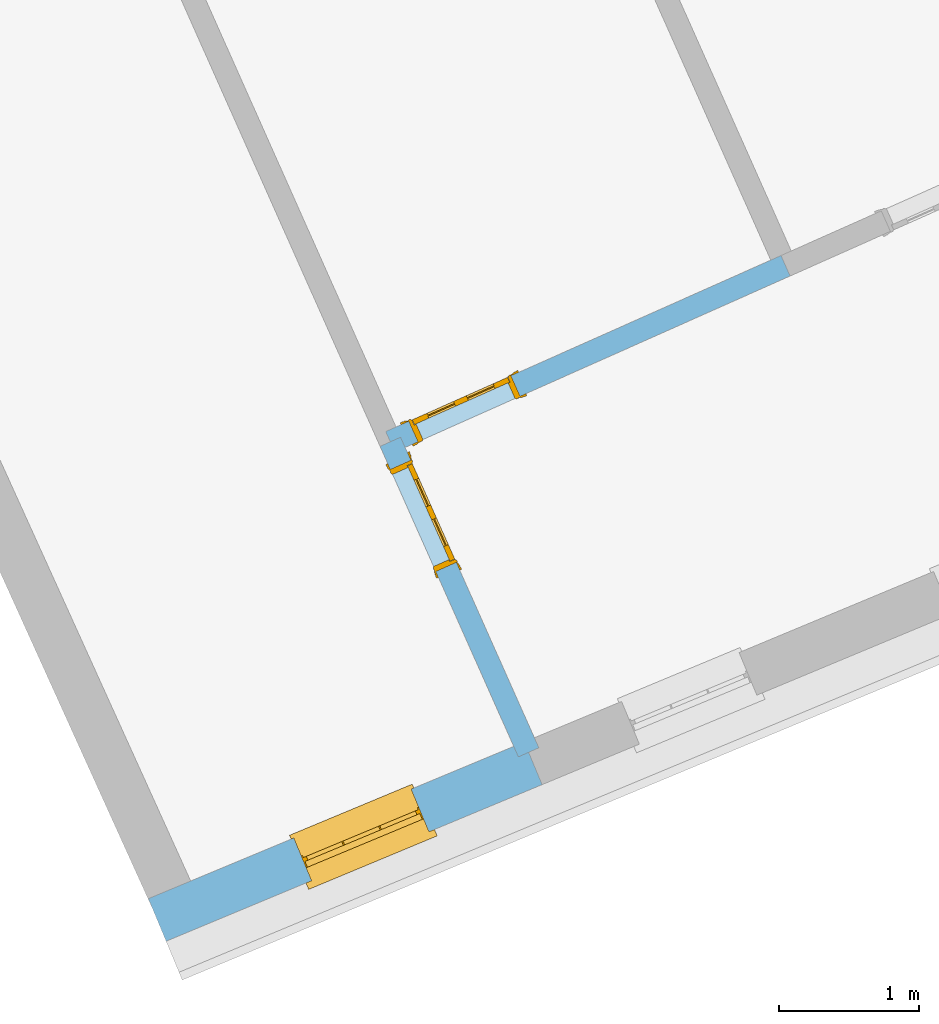
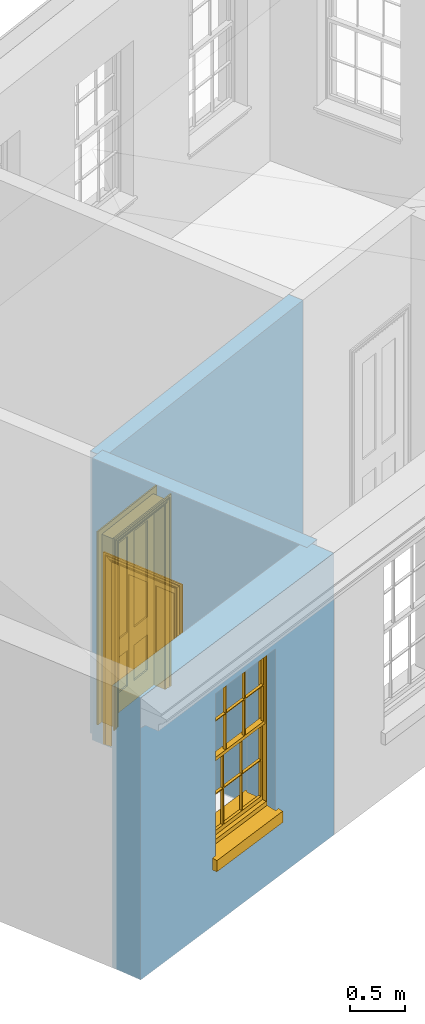
# One storey, part 2 of 10: 2 doors, 1 window, 3 openings, plus 3 elements that do not belong to this part.
"""IFC2X3 building model written with IfcOpenShell, lengths in metres."""

from ifc_helpers import new_model, si_unit, frame, origin, place, context, subcontext, project, spatial, polyline, outline, extrude, faceted_brep, material, layer, layer_set, layer_usage, element, fill, save


model = new_model("IFC2X3")

# Units and contexts
model_context = context("Model", 3, world=origin())
body_context = subcontext(model_context, "Body", "Model", "MODEL_VIEW")
ifc_project = project(units=[si_unit("PLANEANGLEUNIT", "RADIAN"), si_unit("MASSUNIT", "GRAM", prefix="KILO"), si_unit("FORCEUNIT", "NEWTON", prefix="KILO"), si_unit("LENGTHUNIT", "METRE")], contexts=[model_context])

# Site, building, storey
site_placement = place(None, origin())
site = spatial("IfcSite", under=ifc_project, at=site_placement, CompositionType="ELEMENT")
building_placement = place(None, origin())
building = spatial("IfcBuilding", under=site, at=building_placement, Name="Building plot-1", CompositionType="ELEMENT")
storey_placement = place(None, frame((0.0, 0.0, 8.45)))
storey = spatial("IfcBuildingStorey", under=building, at=storey_placement, Name="Floor 2", CompositionType="ELEMENT", Elevation=8.45)

# Wall, opening, window
ifc_material_1 = material(Name="Masonry")
ifc_layer_1 = layer(ifc_material_1, 0.33, ventilated=False)
ifc_layer_set_1 = layer_set([ifc_layer_1], Name="My Wall")
ifc_layer_usage_1 = layer_usage(ifc_layer_set_1, "AXIS2", "NEGATIVE", 0.08)
wall_1_placement = place(storey_placement, origin())
wall_1 = element("IfcWallStandardCase", 1, at=wall_1_placement, inside=storey, material=ifc_layer_usage_1, Name="exterior", context=body_context, shape_type="SweptSolid", body=[
    extrude(outline(polyline([(21.5557040167118, 40.2736905266135), (21.6826157364214, 39.9690704100743), (24.3699915253352, 41.0886927342715), (24.2430798056257, 41.3933128508107), (21.5557040167118, 40.2736905266135)])), origin(), (0.0, 0.0, 1.0), 3.15),
])
opening_1_placement = place(storey_placement, frame((0.0, 0.0, 0.75)))
opening_1 = element("IfcOpeningElement", 2, at=opening_1_placement, cuts=wall_1, Name="Opening", ObjectType="Opening", context=body_context, shape_type="SweptSolid", body=[
    extrude(outline(polyline([(22.7216835143391, 40.4019698524633), (23.5616965629775, 40.7519385340866), (23.434784843268, 41.0565586506259), (22.5947717946295, 40.7065899690026), (22.7216835143391, 40.4019698524633)])), origin(), (0.0, 0.0, 1.0), 1.82),
])
window_placement = place(storey_placement, frame((22.6255382721349, 40.6327426680233, 0.75), z_axis=(0.0, 0.0, 1.0), x_axis=(0.840013048638443, 0.349968681623302, 0.0)))
window = element("IfcWindow", 3, at=window_placement, inside=storey, Name="bedroom outside window", OverallHeight=1.82, OverallWidth=0.91, context=body_context, shape_type="Brep", held_by="IfcProductRepresentation", body=[
    faceted_brep([(0.033125, -0.105, 0.975209), (0.01, -0.105, 0.975209), (0.033125, -0.105, 1.376042), (0.876875, -0.105, 0.975209), (0.876875, -0.105, 1.376042), (0.9, -0.105, 0.975209), (0.876875, -0.105, 1.386042), (0.876875, -0.105, 1.786875), (0.9, -0.105, 1.81), (0.033125, -0.105, 1.786875), (0.033125, -0.105, 1.386042), (0.01, -0.105, 1.81), (0.876875, -0.135, 1.376042), (0.876875, -0.135, 0.975209), (0.9, -0.135, 0.937083), (0.033125, -0.135, 1.786875), (0.01, -0.135, 1.81), (0.033125, -0.135, 1.386042), (0.01, -0.135, 0.937083), (0.033125, -0.135, 0.975209), (0.033125, -0.135, 1.376042), (0.876875, -0.135, 1.786875), (0.876875, -0.135, 1.386042), (0.9, -0.135, 1.81), (0.033125, -0.105, 0.937083), (0.01, -0.105, 0.937083), (0.033125, -0.105, 0.53625), (0.876875, -0.105, 0.937083), (0.876875, -0.105, 0.53625), (0.9, -0.105, 0.937083), (0.876875, -0.105, 0.52625), (0.876875, -0.105, 0.125417), (0.9, -0.105, 0.077167), (0.033125, -0.105, 0.125417), (0.033125, -0.105, 0.52625), (0.01, -0.105, 0.077167), (-0.0425, -0.25, 0.01), (-0.0425, -0.3, 0.001667), (0.0, -0.25, 0.01), (0.9525, -0.25, 0.01), (0.91, -0.25, 0.01), (0.9525, -0.3, 0.001667), (-0.02, 0.08, 0.077167), (0.0, 0.08, 0.077167), (-0.02, 0.11, 0.077167), (0.0, -0.06, 0.077167), (0.01, -0.06, 0.077167), (0.91, -0.06, 0.077167), (0.91, 0.08, 0.077167), (0.9, -0.06, 0.077167), (0.93, 0.08, 0.077167), (0.93, 0.11, 0.077167), (0.01, -0.075, 0.975209), (0.9, -0.075, 0.975209), (0.876875, -0.075, 0.125417), (0.876875, -0.075, 0.52625), (0.9, -0.075, 0.077167), (0.876875, -0.075, 0.53625), (0.876875, -0.075, 0.937083), (0.033125, -0.075, 0.125417), (0.01, -0.075, 0.077167), (0.033125, -0.075, 0.52625), (0.033125, -0.075, 0.937083), (0.033125, -0.075, 0.53625), (-0.02, 0.08, 0.052167), (-0.02, 0.11, 0.052167), (0.93, 0.11, 0.052167), (0.93, 0.08, 0.052167), (0.91, 0.08, 0.052167), (0.0, 0.08, 0.052167), (0.91, -0.15, 0.026667), (0.0, -0.15, 0.026667), (-0.0425, -0.3, -0.123333), (0.9525, -0.3, -0.123333), (-0.0425, -0.25, -0.123333), (0.9525, -0.25, -0.123333), (0.01, -0.06, 1.81), (0.9, -0.06, 1.81), (0.0, -0.06, 1.82), (0.91, -0.06, 1.82), (0.01, -0.15, 0.077167), (0.9, -0.15, 0.077167), (0.592292, -0.105, 0.125417), (0.592292, -0.075, 0.125417), (0.317708, -0.075, 0.125417), (0.317708, -0.105, 0.125417), (0.592292, -0.105, 0.53625), (0.317708, -0.105, 0.53625), (0.317708, -0.105, 0.52625), (0.592292, -0.105, 0.52625), (0.592292, -0.075, 0.53625), (0.317708, -0.075, 0.53625), (0.592292, -0.135, 1.386042), (0.592292, -0.105, 1.386042), (0.317708, -0.105, 1.386042), (0.317708, -0.135, 1.386042), (0.317708, -0.135, 1.376042), (0.592292, -0.135, 1.376042), (0.317708, -0.105, 1.376042), (0.592292, -0.105, 1.376042), (0.602292, -0.135, 1.376042), (0.592292, -0.135, 0.975209), (0.602292, -0.135, 0.975209), (0.602292, -0.105, 0.975209), (0.592292, -0.105, 0.975209), (0.602292, -0.105, 1.376042), (0.602292, -0.075, 0.53625), (0.602292, -0.105, 0.53625), (0.317708, -0.075, 0.52625), (0.307708, -0.075, 0.125417), (0.307708, -0.075, 0.52625), (0.602292, -0.075, 0.52625), (0.602292, -0.075, 0.125417), (0.592292, -0.075, 0.52625), (0.307708, -0.075, 0.53625), (0.317708, -0.075, 0.937083), (0.307708, -0.075, 0.937083), (0.602292, -0.075, 0.937083), (0.592292, -0.075, 0.937083), (0.307708, -0.105, 0.52625), (0.307708, -0.105, 0.125417), (0.307708, -0.105, 0.53625), (0.307708, -0.105, 0.937083), (0.592292, -0.105, 0.937083), (0.317708, -0.105, 0.937083), (0.602292, -0.105, 0.937083), (0.602292, -0.105, 0.52625), (0.602292, -0.105, 0.125417), (0.307708, -0.135, 1.386042), (0.307708, -0.135, 1.376042), (0.307708, -0.135, 0.975209), (0.317708, -0.135, 0.975209), (0.317708, -0.135, 1.786875), (0.307708, -0.135, 1.786875), (0.602292, -0.135, 1.786875), (0.592292, -0.135, 1.786875), (0.602292, -0.135, 1.386042), (0.602292, -0.105, 1.386042), (0.307708, -0.105, 1.386042), (0.307708, -0.105, 1.786875), (0.317708, -0.105, 1.786875), (0.592292, -0.105, 1.786875), (0.602292, -0.105, 1.786875), (0.307708, -0.105, 1.376042), (0.317708, -0.105, 0.975209), (0.307708, -0.105, 0.975209), (0.91, -0.15, 1.82), (0.9, -0.15, 1.81), (0.01, -0.15, 1.81), (0.0, -0.15, 1.82), (0.91, -0.25, 0.0), (0.0, -0.25, 0.0), (0.91, 0.08, 0.0), (0.0, 0.08, 0.0)], [[[0, 1, 2]], [[3, 4, 5]], [[6, 7, 8]], [[9, 10, 11]], [[12, 13, 14]], [[15, 16, 17]], [[18, 19, 20]], [[21, 22, 23]], [[24, 25, 26]], [[27, 28, 29]], [[30, 31, 32]], [[33, 34, 35]], [[14, 27, 29]], [[25, 24, 18]], [[36, 37, 38]], [[39, 40, 41]], [[42, 43, 44]], [[45, 46, 43]], [[47, 48, 49]], [[50, 51, 48]], [[1, 0, 52]], [[5, 53, 3]], [[54, 55, 56]], [[57, 58, 53]], [[59, 60, 61]], [[62, 63, 52]], [[48, 43, 46, 49]], [[51, 44, 43, 48]], [[64, 42, 44, 65]], [[65, 44, 51, 66]], [[66, 51, 50, 67]], [[65, 66, 68, 69]], [[60, 56, 49, 46]], [[70, 71, 38, 40]], [[37, 41, 40, 38]], [[37, 72, 73, 41]], [[74, 75, 73, 72]], [[8, 11, 76, 77]], [[76, 78, 79, 77]], [[32, 35, 80, 81]], [[81, 80, 71, 70]], [[82, 83, 84, 85]], [[86, 87, 88, 89]], [[86, 90, 91, 87]], [[92, 93, 94, 95]], [[92, 95, 96, 97]], [[96, 98, 99, 97]], [[100, 97, 101, 102]], [[103, 104, 99, 105]], [[97, 99, 104, 101]], [[102, 103, 105, 100]], [[28, 57, 106, 107]], [[108, 84, 109, 110]], [[111, 112, 83, 113]], [[114, 110, 61, 63]], [[90, 113, 108, 91]], [[115, 91, 114, 116]], [[117, 106, 90, 118]], [[111, 106, 57, 55]], [[119, 110, 109, 120]], [[34, 61, 110, 119]], [[89, 113, 83, 82]], [[88, 108, 113, 89]], [[85, 84, 108, 88]], [[121, 114, 63, 26]], [[122, 116, 114, 121]], [[123, 118, 90, 86]], [[87, 91, 115, 124]], [[107, 106, 117, 125]], [[126, 111, 55, 30]], [[127, 112, 111, 126]], [[126, 30, 28, 107]], [[88, 119, 120, 85]], [[126, 89, 82, 127]], [[125, 123, 86, 107]], [[121, 26, 34, 119]], [[124, 122, 121, 87]], [[128, 17, 20, 129]], [[96, 129, 130, 131]], [[132, 133, 128, 95]], [[134, 135, 92, 136]], [[100, 12, 22, 136]], [[137, 6, 4, 105]], [[94, 138, 139, 140]], [[137, 93, 141, 142]], [[99, 98, 94, 93]], [[143, 2, 10, 138]], [[144, 145, 143, 98]], [[129, 143, 145, 130]], [[20, 2, 143, 129]], [[131, 144, 98, 96]], [[128, 138, 10, 17]], [[133, 139, 138, 128]], [[135, 141, 93, 92]], [[95, 94, 140, 132]], [[22, 6, 137, 136]], [[136, 137, 142, 134]], [[100, 105, 4, 12]], [[107, 86, 89, 126]], [[106, 111, 113, 90]], [[91, 108, 110, 114]], [[87, 121, 119, 88]], [[97, 100, 136, 92]], [[129, 96, 95, 128]], [[98, 143, 138, 94]], [[105, 99, 93, 137]], [[131, 101, 104, 144]], [[124, 115, 118, 123]], [[132, 140, 141, 135]], [[120, 109, 59, 33]], [[15, 9, 139, 133]], [[134, 142, 7, 21]], [[31, 54, 112, 127]], [[36, 74, 72, 37]], [[39, 41, 73, 75]], [[18, 14, 101, 131]], [[23, 16, 132, 135]], [[83, 56, 60, 84]], [[52, 53, 118, 115]], [[53, 52, 144, 104]], [[11, 8, 141, 140]], [[14, 18, 124, 123]], [[2, 1, 11, 10]], [[8, 5, 4, 6]], [[57, 53, 56, 55]], [[60, 52, 63, 61]], [[26, 25, 35, 34]], [[32, 29, 28, 30]], [[14, 23, 22, 12]], [[18, 20, 17, 16]], [[19, 0, 2, 20]], [[17, 10, 9, 15]], [[12, 4, 3, 13]], [[21, 7, 6, 22]], [[27, 58, 57, 28]], [[30, 55, 54, 31]], [[33, 59, 61, 34]], [[26, 63, 62, 24]], [[5, 8, 77, 53]], [[76, 11, 1, 52]], [[46, 45, 78, 76]], [[49, 77, 79, 47]], [[70, 146, 147, 81]], [[71, 80, 148, 149]], [[19, 130, 145, 0]], [[102, 13, 3, 103]], [[116, 122, 24, 62]], [[29, 32, 81, 14]], [[80, 35, 25, 18]], [[60, 46, 76, 52]], [[77, 49, 56, 53]], [[23, 14, 81, 147]], [[16, 148, 80, 18]], [[35, 85, 120]], [[120, 33, 35]], [[127, 82, 32]], [[32, 31, 127]], [[32, 82, 85, 35]], [[102, 101, 14]], [[14, 13, 102]], [[18, 131, 130]], [[130, 19, 18]], [[134, 21, 23]], [[23, 135, 134]], [[16, 15, 133]], [[133, 132, 16]], [[11, 140, 139]], [[139, 9, 11]], [[142, 141, 8]], [[8, 7, 142]], [[23, 147, 148, 16]], [[146, 149, 148, 147]], [[52, 115, 116]], [[116, 62, 52]], [[118, 53, 117]], [[58, 117, 53]], [[27, 125, 117, 58]], [[56, 83, 112]], [[112, 54, 56]], [[109, 84, 60]], [[60, 59, 109]], [[125, 27, 14]], [[14, 123, 125]], [[122, 124, 18]], [[18, 24, 122]], [[145, 144, 52]], [[52, 0, 145]], [[103, 3, 53]], [[53, 104, 103]], [[79, 78, 149, 146]], [[78, 45, 71, 149]], [[146, 70, 47, 79]], [[150, 75, 74, 151]], [[68, 66, 67]], [[48, 68, 67, 50]], [[69, 64, 65]], [[42, 64, 69, 43]], [[69, 68, 152, 153]], [[70, 68, 48, 47]], [[150, 152, 68, 70]], [[43, 69, 71, 45]], [[69, 153, 151, 71]], [[152, 150, 151, 153]], [[38, 151, 74, 36]], [[71, 151, 38]], [[39, 75, 150, 40]], [[40, 150, 70]]]),
])
fill(opening_1, window)

# Wall, opening, door
ifc_material_2 = material(Name="Masonry")
ifc_layer_2 = layer(ifc_material_2, 0.16, ventilated=False)
ifc_layer_set_2 = layer_set([ifc_layer_2], Name="My Wall")
ifc_layer_usage_2 = layer_usage(ifc_layer_set_2, "AXIS2", "NEGATIVE", 0.08)
wall_2_placement = place(storey_placement, origin())
wall_2 = element("IfcWallStandardCase", 4, at=wall_2_placement, inside=storey, material=ifc_layer_usage_2, Name="interior", context=body_context, shape_type="SweptSolid", body=[
    extrude(outline(polyline([(23.2527273326909, 43.6122835731308), (23.3178206552539, 43.4661231839766), (26.1430137461052, 44.7243382600993), (26.0779204235422, 44.8704986492535), (23.2527273326909, 43.6122835731308)])), origin(), (0.0, 0.0, 1.0), 3.15),
])
opening_2_placement = place(storey_placement, frame((0.0, 0.0, 0.0199999999999996)))
opening_2 = element("IfcOpeningElement", 5, at=opening_2_placement, cuts=wall_2, Name="Opening", ObjectType="Opening", context=body_context, shape_type="SweptSolid", body=[
    extrude(outline(polyline([(23.4822510930524, 43.5393531718601), (24.2130530388233, 43.8648197846754), (24.1479597162602, 44.0109801738296), (23.4171577704893, 43.6855135610142), (23.4822510930524, 43.5393531718601)])), origin(), (0.0, 0.0, 1.0), 2.1),
])
door_1_placement = place(storey_placement, frame((23.4497044317708, 43.6124333664372, 0.0199999999999996), z_axis=(0.0, 0.0, 1.0), x_axis=(0.730801945770875, 0.325466612815354, 0.0)))
door_1 = element("IfcDoor", 6, at=door_1_placement, inside=storey, Name="bedroom inside door", OverallHeight=2.1, OverallWidth=0.8, context=body_context, shape_type="Brep", held_by="IfcProductRepresentation", body=[
    faceted_brep([(0.773, 0.08, 1.895), (0.66, 0.08, 1.895), (0.66, 0.08, 2.073), (0.773, 0.08, 2.073), (0.773, 0.08, 0.82), (0.66, 0.08, 0.82), (0.45, 0.08, 1.895), (0.45, 0.08, 2.073), (0.773, 0.08, 0.62), (0.66, 0.08, 0.62), (0.66, 0.065, 0.82), (0.66, 0.065, 1.895), (0.45, 0.065, 1.895), (0.35, 0.08, 1.895), (0.35, 0.08, 2.073), (0.773, 0.08, 0.225), (0.66, 0.08, 0.225), (0.45, 0.08, 0.62), (0.45, 0.08, 0.82), (0.45, 0.065, 0.82), (0.35, 0.08, 0.82), (0.14, 0.08, 2.073), (0.14, 0.08, 1.895), (0.773, 0.08, 0.0), (0.66, 0.08, 0.0), (0.66, 0.065, 0.225), (0.66, 0.065, 0.62), (0.45, 0.065, 0.62), (0.35, 0.08, 0.62), (0.35, 0.065, 0.82), (0.35, 0.065, 1.895), (0.14, 0.065, 1.895), (0.027, 0.08, 2.073), (0.027, 0.08, 1.895), (0.773, 0.042, 0.0), (0.66, 0.042, 0.0), (0.45, 0.08, 0.0), (0.45, 0.08, 0.225), (0.45, 0.065, 0.225), (0.35, 0.08, 0.225), (0.14, 0.08, 0.82), (0.14, 0.08, 0.62), (0.14, 0.065, 0.82), (0.027, 0.08, 0.82), (0.773, 0.042, 0.225), (0.66, 0.042, 0.225), (0.45, 0.042, 0.0), (0.35, 0.08, 0.0), (0.35, 0.065, 0.225), (0.35, 0.065, 0.62), (0.14, 0.065, 0.62), (0.027, 0.08, 0.62), (0.773, 0.042, 0.62), (0.66, 0.042, 0.62), (0.45, 0.042, 0.225), (0.35, 0.042, 0.0), (0.14, 0.08, 0.225), (0.14, 0.08, 0.0), (0.14, 0.065, 0.225), (0.027, 0.08, 0.225), (0.773, 0.042, 0.82), (0.66, 0.042, 0.82), (0.66, 0.057, 0.62), (0.66, 0.057, 0.225), (0.45, 0.057, 0.225), (0.35, 0.042, 0.225), (0.14, 0.042, 0.0), (0.027, 0.08, 0.0), (0.773, 0.042, 1.895), (0.66, 0.042, 1.895), (0.45, 0.042, 0.62), (0.45, 0.042, 0.82), (0.45, 0.057, 0.62), (0.35, 0.042, 0.62), (0.14, 0.042, 0.225), (0.027, 0.042, 0.0), (0.773, 0.042, 2.073), (0.66, 0.042, 2.073), (0.66, 0.057, 1.895), (0.66, 0.057, 0.82), (0.45, 0.057, 0.82), (0.35, 0.042, 0.82), (0.35, 0.057, 0.62), (0.35, 0.057, 0.225), (0.14, 0.057, 0.225), (0.027, 0.042, 0.225), (0.45, 0.042, 1.895), (0.45, 0.042, 2.073), (0.45, 0.057, 1.895), (0.35, 0.042, 1.895), (0.14, 0.042, 0.82), (0.14, 0.042, 0.62), (0.14, 0.057, 0.62), (0.027, 0.042, 0.62), (0.35, 0.042, 2.073), (0.35, 0.057, 1.895), (0.35, 0.057, 0.82), (0.14, 0.057, 0.82), (0.027, 0.042, 0.82), (0.14, 0.042, 2.073), (0.14, 0.042, 1.895), (0.14, 0.057, 1.895), (0.027, 0.042, 1.895), (0.027, 0.042, 2.073), (0.02, 0.085, 0.0), (0.005, 0.09, 0.0), (0.005, 0.09, 2.095), (0.02, 0.085, 2.08), (0.02, 0.08, 0.0), (0.0, 0.085, 0.0), (0.0, 0.085, 2.1), (0.795, 0.09, 2.095), (0.78, 0.085, 2.08), (0.02, 0.08, 2.08), (0.0, 0.08, 0.0), (-0.032, 0.095, 0.0), (-0.032, 0.095, 2.132), (0.8, 0.085, 2.1), (0.795, 0.09, 0.0), (0.78, 0.085, 0.0), (0.78, 0.08, 2.08), (0.04, 0.04, 0.0), (0.025, 0.04, 0.0), (0.025, 0.04, 2.075), (0.04, 0.04, 2.06), (-0.04, 0.09, 0.0), (-0.04, 0.09, 2.14), (0.832, 0.095, 2.132), (0.8, 0.085, 0.0), (0.78, 0.08, 0.0), (0.8, 0.08, 0.0), (0.86, 0.08, 0.0), (0.86, 0.08, 2.16), (0.8, 0.08, 2.1), (-0.06, 0.08, 2.16), (0.0, 0.08, 2.1), (-0.06, 0.08, 0.0), (-0.04, 0.095, 0.0), (-0.04, 0.095, 2.14), (0.84, 0.09, 2.14), (0.832, 0.095, 0.0), (0.84, 0.09, 0.0), (0.86, 0.095, 0.0), (0.86, 0.095, 2.16), (-0.06, 0.095, 2.16), (-0.06, 0.095, 0.0), (0.84, 0.095, 0.0), (0.84, 0.095, 2.14), (-0.025, -0.095, 0.0), (-0.025, -0.09, 0.0), (-0.025, -0.09, 2.125), (-0.025, -0.095, 2.125), (-0.017, -0.095, 0.0), (-0.017, -0.095, 2.117), (0.825, -0.09, 2.125), (0.825, -0.095, 2.125), (0.825, -0.095, 0.0), (0.845, -0.095, 0.0), (-0.045, -0.095, 2.145), (-0.045, -0.095, 0.0), (0.845, -0.095, 2.145), (0.015, -0.085, 0.0), (0.015, -0.085, 2.085), (0.817, -0.095, 2.117), (0.825, -0.09, 0.0), (0.845, -0.08, 0.0), (0.845, -0.08, 2.145), (-0.045, -0.08, 2.145), (-0.045, -0.08, 0.0), (0.02, -0.09, 0.0), (0.02, -0.09, 2.08), (0.785, -0.085, 2.085), (0.817, -0.095, 0.0), (0.8, -0.08, 0.0), (0.8, -0.08, 2.1), (0.0, -0.08, 2.1), (0.0, -0.08, 0.0), (0.035, -0.085, 0.0), (0.035, -0.085, 2.065), (0.78, -0.09, 2.08), (0.785, -0.085, 0.0), (0.775, 0.04, 2.075), (0.76, 0.04, 2.06), (0.035, -0.08, 2.065), (0.035, -0.08, 0.0), (0.765, -0.085, 2.065), (0.78, -0.09, 0.0), (0.765, -0.08, 0.0), (0.765, -0.08, 2.065), (0.765, -0.085, 0.0), (0.04, -0.08, 2.06), (0.04, -0.08, 0.0), (0.76, -0.08, 2.06), (0.76, -0.08, 0.0), (0.76, 0.04, 0.0), (0.775, 0.04, 0.0), (0.025, 0.08, 0.0), (0.025, 0.08, 2.075), (0.775, 0.08, 0.0), (0.775, 0.08, 2.075)], [[[0, 1, 2, 3]], [[1, 0, 4, 5]], [[1, 6, 7, 2]], [[8, 9, 5, 4]], [[1, 5, 10, 11]], [[6, 1, 11, 12]], [[6, 13, 14, 7]], [[15, 16, 9, 8]], [[9, 17, 18, 5]], [[5, 18, 19, 10]], [[10, 19, 12, 11]], [[18, 6, 12, 19]], [[18, 20, 13, 6]], [[21, 14, 13, 22]], [[23, 24, 16, 15]], [[9, 16, 25, 26]], [[17, 9, 26, 27]], [[17, 28, 20, 18]], [[13, 20, 29, 30]], [[22, 13, 30, 31]], [[32, 21, 22, 33]], [[34, 35, 24, 23]], [[24, 36, 37, 16]], [[16, 37, 38, 25]], [[25, 38, 27, 26]], [[37, 17, 27, 38]], [[37, 39, 28, 17]], [[40, 20, 28, 41]], [[20, 40, 42, 29]], [[31, 30, 29, 42]], [[40, 22, 31, 42]], [[33, 22, 40, 43]], [[35, 34, 44, 45]], [[35, 46, 36, 24]], [[36, 47, 39, 37]], [[28, 39, 48, 49]], [[41, 28, 49, 50]], [[43, 40, 41, 51]], [[45, 44, 52, 53]], [[46, 35, 45, 54]], [[46, 55, 47, 36]], [[56, 39, 47, 57]], [[39, 56, 58, 48]], [[50, 49, 48, 58]], [[56, 41, 50, 58]], [[51, 41, 56, 59]], [[53, 52, 60, 61]], [[45, 53, 62, 63]], [[54, 45, 63, 64]], [[55, 46, 54, 65]], [[55, 66, 57, 47]], [[59, 56, 57, 67]], [[61, 60, 68, 69]], [[70, 53, 61, 71]], [[53, 70, 72, 62]], [[72, 64, 63, 62]], [[70, 54, 64, 72]], [[65, 54, 70, 73]], [[65, 74, 66, 55]], [[67, 57, 66, 75]], [[69, 68, 76, 77]], [[61, 69, 78, 79]], [[71, 61, 79, 80]], [[73, 70, 71, 81]], [[65, 73, 82, 83]], [[74, 65, 83, 84]], [[74, 85, 75, 66]], [[86, 69, 77, 87]], [[69, 86, 88, 78]], [[88, 80, 79, 78]], [[86, 71, 80, 88]], [[81, 71, 86, 89]], [[73, 81, 90, 91]], [[73, 91, 92, 82]], [[83, 82, 92, 84]], [[91, 74, 84, 92]], [[91, 93, 85, 74]], [[89, 86, 87, 94]], [[81, 89, 95, 96]], [[90, 81, 96, 97]], [[90, 98, 93, 91]], [[94, 99, 100, 89]], [[89, 100, 101, 95]], [[101, 97, 96, 95]], [[100, 90, 97, 101]], [[100, 102, 98, 90]], [[99, 103, 102, 100]], [[32, 103, 99, 21]], [[102, 103, 32, 33]], [[98, 102, 33, 43]], [[21, 99, 94, 14]], [[94, 87, 7, 14]], [[7, 87, 77, 2]], [[76, 3, 2, 77]], [[43, 51, 93, 98]], [[51, 59, 85, 93]], [[67, 75, 85, 59]], [[34, 23, 15, 44]], [[44, 15, 8, 52]], [[52, 8, 4, 60]], [[0, 68, 60, 4]], [[0, 3, 76, 68]], [[104, 105, 106, 107]], [[104, 108, 109, 105]], [[105, 109, 110, 106]], [[107, 106, 111, 112]], [[107, 113, 108, 104]], [[114, 109, 108]], [[109, 115, 116, 110]], [[106, 110, 117, 111]], [[112, 111, 118, 119]], [[113, 107, 112, 120]], [[121, 122, 123, 124]], [[115, 109, 114, 125]], [[115, 125, 126, 116]], [[110, 116, 127, 117]], [[111, 117, 128, 118]], [[118, 128, 129, 119]], [[120, 112, 119, 129]], [[130, 129, 128]], [[130, 131, 132, 133]], [[133, 132, 134, 135]], [[135, 134, 136, 114]], [[136, 125, 114]], [[125, 137, 138, 126]], [[116, 126, 139, 127]], [[117, 127, 140, 128]], [[141, 130, 128, 140]], [[131, 130, 141]], [[131, 142, 143, 132]], [[132, 143, 144, 134]], [[134, 144, 145, 136]], [[137, 125, 136, 145]], [[143, 142, 146]], [[143, 146, 147]], [[137, 145, 144]], [[143, 147, 138]], [[138, 137, 144]], [[143, 138, 144]], [[126, 138, 147, 139]], [[127, 139, 141, 140]], [[142, 131, 141, 146]], [[139, 147, 146, 141]], [[148, 149, 150, 151]], [[149, 152, 153, 150]], [[151, 150, 154, 155]], [[155, 156, 157]], [[158, 159, 148]], [[158, 148, 151]], [[155, 157, 160]], [[158, 151, 155]], [[155, 160, 158]], [[152, 161, 162, 153]], [[150, 153, 163, 154]], [[155, 154, 164, 156]], [[156, 164, 165, 157]], [[157, 165, 166, 160]], [[160, 166, 167, 158]], [[158, 167, 168, 159]], [[161, 169, 170, 162]], [[153, 162, 171, 163]], [[154, 163, 172, 164]], [[165, 164, 173]], [[165, 173, 174, 166]], [[166, 174, 175, 167]], [[167, 175, 176, 168]], [[169, 177, 178, 170]], [[162, 170, 179, 171]], [[163, 171, 180, 172]], [[172, 180, 173, 164]], [[124, 123, 181, 182]], [[183, 178, 177, 184]], [[170, 178, 185, 179]], [[171, 179, 186, 180]], [[187, 173, 180]], [[185, 188, 187, 189]], [[188, 185, 178, 183]], [[179, 185, 189, 186]], [[189, 187, 180, 186]], [[190, 183, 184, 191]], [[192, 188, 183, 190]], [[191, 184, 122, 121]], [[124, 190, 191, 121]], [[193, 187, 188, 192]], [[182, 192, 190, 124]], [[184, 176, 122]], [[194, 195, 187, 193]], [[192, 182, 194, 193]], [[161, 176, 184]], [[114, 108, 122, 176]], [[173, 187, 195]], [[152, 149, 176, 161]], [[169, 161, 184, 177]], [[196, 122, 108]], [[176, 175, 135, 114]], [[173, 195, 129, 130]], [[176, 149, 168]], [[123, 122, 196, 197]], [[196, 108, 113, 197]], [[175, 174, 133, 135]], [[198, 129, 195]], [[133, 174, 173, 130]], [[159, 168, 149, 148]], [[181, 123, 197, 199]], [[197, 113, 120, 199]], [[199, 120, 129, 198]], [[195, 181, 199, 198]], [[195, 194, 182, 181]]]),
])
fill(opening_2, door_1)

wall_3_placement = place(storey_placement, origin())
wall_3 = element("IfcWallStandardCase", 7, at=wall_3_placement, inside=storey, material=ifc_layer_usage_2, Name="interior", context=body_context, shape_type="SweptSolid", body=[
    extrude(outline(polyline([(23.3583541885495, 43.5717500398352), (23.2121937993953, 43.5066567172722), (24.2007660885539, 41.28691888855), (24.3469264777081, 41.352012211113), (23.3583541885495, 43.5717500398352)])), origin(), (0.0, 0.0, 1.0), 3.15),
])
opening_3_placement = place(storey_placement, frame((0.0, 0.0, 0.0199999999999996)))
opening_3 = element("IfcOpeningElement", 8, at=opening_3_placement, cuts=wall_3, Name="Opening", ObjectType="Opening", context=body_context, shape_type="SweptSolid", body=[
    extrude(outline(polyline([(23.2854237872788, 43.3422262794737), (23.6108904000941, 42.6114243337028), (23.7570507892483, 42.6765176562659), (23.4315841764329, 43.4073196020368), (23.2854237872788, 43.3422262794737)])), origin(), (0.0, 0.0, 1.0), 2.1),
])
door_2_placement = place(storey_placement, frame((23.3585039818559, 43.3747729407552, 0.0199999999999996), z_axis=(0.0, 0.0, 1.0), x_axis=(0.325466612815337, -0.730801945770885, 0.0)))
door_2 = element("IfcDoor", 9, at=door_2_placement, inside=storey, Name="bedroom inside door", OverallHeight=2.1, OverallWidth=0.8, context=body_context, shape_type="Brep", held_by="IfcProductRepresentation", body=[
    faceted_brep([(0.773, 0.08, 1.895), (0.66, 0.08, 1.895), (0.66, 0.08, 2.073), (0.773, 0.08, 2.073), (0.773, 0.08, 0.82), (0.66, 0.08, 0.82), (0.45, 0.08, 1.895), (0.45, 0.08, 2.073), (0.773, 0.08, 0.62), (0.66, 0.08, 0.62), (0.66, 0.065, 0.82), (0.66, 0.065, 1.895), (0.45, 0.065, 1.895), (0.35, 0.08, 1.895), (0.35, 0.08, 2.073), (0.773, 0.08, 0.225), (0.66, 0.08, 0.225), (0.45, 0.08, 0.62), (0.45, 0.08, 0.82), (0.45, 0.065, 0.82), (0.35, 0.08, 0.82), (0.14, 0.08, 2.073), (0.14, 0.08, 1.895), (0.773, 0.08, 0.0), (0.66, 0.08, 0.0), (0.66, 0.065, 0.225), (0.66, 0.065, 0.62), (0.45, 0.065, 0.62), (0.35, 0.08, 0.62), (0.35, 0.065, 0.82), (0.35, 0.065, 1.895), (0.14, 0.065, 1.895), (0.027, 0.08, 2.073), (0.027, 0.08, 1.895), (0.773, 0.042, 0.0), (0.66, 0.042, 0.0), (0.45, 0.08, 0.0), (0.45, 0.08, 0.225), (0.45, 0.065, 0.225), (0.35, 0.08, 0.225), (0.14, 0.08, 0.82), (0.14, 0.08, 0.62), (0.14, 0.065, 0.82), (0.027, 0.08, 0.82), (0.773, 0.042, 0.225), (0.66, 0.042, 0.225), (0.45, 0.042, 0.0), (0.35, 0.08, 0.0), (0.35, 0.065, 0.225), (0.35, 0.065, 0.62), (0.14, 0.065, 0.62), (0.027, 0.08, 0.62), (0.773, 0.042, 0.62), (0.66, 0.042, 0.62), (0.45, 0.042, 0.225), (0.35, 0.042, 0.0), (0.14, 0.08, 0.225), (0.14, 0.08, 0.0), (0.14, 0.065, 0.225), (0.027, 0.08, 0.225), (0.773, 0.042, 0.82), (0.66, 0.042, 0.82), (0.66, 0.057, 0.62), (0.66, 0.057, 0.225), (0.45, 0.057, 0.225), (0.35, 0.042, 0.225), (0.14, 0.042, 0.0), (0.027, 0.08, 0.0), (0.773, 0.042, 1.895), (0.66, 0.042, 1.895), (0.45, 0.042, 0.62), (0.45, 0.042, 0.82), (0.45, 0.057, 0.62), (0.35, 0.042, 0.62), (0.14, 0.042, 0.225), (0.027, 0.042, 0.0), (0.773, 0.042, 2.073), (0.66, 0.042, 2.073), (0.66, 0.057, 1.895), (0.66, 0.057, 0.82), (0.45, 0.057, 0.82), (0.35, 0.042, 0.82), (0.35, 0.057, 0.62), (0.35, 0.057, 0.225), (0.14, 0.057, 0.225), (0.027, 0.042, 0.225), (0.45, 0.042, 1.895), (0.45, 0.042, 2.073), (0.45, 0.057, 1.895), (0.35, 0.042, 1.895), (0.14, 0.042, 0.82), (0.14, 0.042, 0.62), (0.14, 0.057, 0.62), (0.027, 0.042, 0.62), (0.35, 0.042, 2.073), (0.35, 0.057, 1.895), (0.35, 0.057, 0.82), (0.14, 0.057, 0.82), (0.027, 0.042, 0.82), (0.14, 0.042, 2.073), (0.14, 0.042, 1.895), (0.14, 0.057, 1.895), (0.027, 0.042, 1.895), (0.027, 0.042, 2.073), (0.02, 0.085, 0.0), (0.005, 0.09, 0.0), (0.005, 0.09, 2.095), (0.02, 0.085, 2.08), (0.02, 0.08, 0.0), (0.0, 0.085, 0.0), (0.0, 0.085, 2.1), (0.795, 0.09, 2.095), (0.78, 0.085, 2.08), (0.02, 0.08, 2.08), (0.0, 0.08, 0.0), (-0.032, 0.095, 0.0), (-0.032, 0.095, 2.132), (0.8, 0.085, 2.1), (0.795, 0.09, 0.0), (0.78, 0.085, 0.0), (0.78, 0.08, 2.08), (0.04, 0.04, 0.0), (0.025, 0.04, 0.0), (0.025, 0.04, 2.075), (0.04, 0.04, 2.06), (-0.04, 0.09, 0.0), (-0.04, 0.09, 2.14), (0.832, 0.095, 2.132), (0.8, 0.085, 0.0), (0.78, 0.08, 0.0), (0.8, 0.08, 0.0), (0.86, 0.08, 0.0), (0.86, 0.08, 2.16), (0.8, 0.08, 2.1), (-0.06, 0.08, 2.16), (0.0, 0.08, 2.1), (-0.06, 0.08, 0.0), (-0.04, 0.095, 0.0), (-0.04, 0.095, 2.14), (0.84, 0.09, 2.14), (0.832, 0.095, 0.0), (0.84, 0.09, 0.0), (0.86, 0.095, 0.0), (0.86, 0.095, 2.16), (-0.06, 0.095, 2.16), (-0.06, 0.095, 0.0), (0.84, 0.095, 0.0), (0.84, 0.095, 2.14), (-0.025, -0.095, 0.0), (-0.025, -0.09, 0.0), (-0.025, -0.09, 2.125), (-0.025, -0.095, 2.125), (-0.017, -0.095, 0.0), (-0.017, -0.095, 2.117), (0.825, -0.09, 2.125), (0.825, -0.095, 2.125), (0.825, -0.095, 0.0), (0.845, -0.095, 0.0), (-0.045, -0.095, 2.145), (-0.045, -0.095, 0.0), (0.845, -0.095, 2.145), (0.015, -0.085, 0.0), (0.015, -0.085, 2.085), (0.817, -0.095, 2.117), (0.825, -0.09, 0.0), (0.845, -0.08, 0.0), (0.845, -0.08, 2.145), (-0.045, -0.08, 2.145), (-0.045, -0.08, 0.0), (0.02, -0.09, 0.0), (0.02, -0.09, 2.08), (0.785, -0.085, 2.085), (0.817, -0.095, 0.0), (0.8, -0.08, 0.0), (0.8, -0.08, 2.1), (0.0, -0.08, 2.1), (0.0, -0.08, 0.0), (0.035, -0.085, 0.0), (0.035, -0.085, 2.065), (0.78, -0.09, 2.08), (0.785, -0.085, 0.0), (0.775, 0.04, 2.075), (0.76, 0.04, 2.06), (0.035, -0.08, 2.065), (0.035, -0.08, 0.0), (0.765, -0.085, 2.065), (0.78, -0.09, 0.0), (0.765, -0.08, 0.0), (0.765, -0.08, 2.065), (0.765, -0.085, 0.0), (0.04, -0.08, 2.06), (0.04, -0.08, 0.0), (0.76, -0.08, 2.06), (0.76, -0.08, 0.0), (0.76, 0.04, 0.0), (0.775, 0.04, 0.0), (0.025, 0.08, 0.0), (0.025, 0.08, 2.075), (0.775, 0.08, 0.0), (0.775, 0.08, 2.075)], [[[0, 1, 2, 3]], [[1, 0, 4, 5]], [[1, 6, 7, 2]], [[8, 9, 5, 4]], [[1, 5, 10, 11]], [[6, 1, 11, 12]], [[6, 13, 14, 7]], [[15, 16, 9, 8]], [[9, 17, 18, 5]], [[5, 18, 19, 10]], [[10, 19, 12, 11]], [[18, 6, 12, 19]], [[18, 20, 13, 6]], [[21, 14, 13, 22]], [[23, 24, 16, 15]], [[9, 16, 25, 26]], [[17, 9, 26, 27]], [[17, 28, 20, 18]], [[13, 20, 29, 30]], [[22, 13, 30, 31]], [[32, 21, 22, 33]], [[34, 35, 24, 23]], [[24, 36, 37, 16]], [[16, 37, 38, 25]], [[25, 38, 27, 26]], [[37, 17, 27, 38]], [[37, 39, 28, 17]], [[40, 20, 28, 41]], [[20, 40, 42, 29]], [[31, 30, 29, 42]], [[40, 22, 31, 42]], [[33, 22, 40, 43]], [[35, 34, 44, 45]], [[35, 46, 36, 24]], [[36, 47, 39, 37]], [[28, 39, 48, 49]], [[41, 28, 49, 50]], [[43, 40, 41, 51]], [[45, 44, 52, 53]], [[46, 35, 45, 54]], [[46, 55, 47, 36]], [[56, 39, 47, 57]], [[39, 56, 58, 48]], [[50, 49, 48, 58]], [[56, 41, 50, 58]], [[51, 41, 56, 59]], [[53, 52, 60, 61]], [[45, 53, 62, 63]], [[54, 45, 63, 64]], [[55, 46, 54, 65]], [[55, 66, 57, 47]], [[59, 56, 57, 67]], [[61, 60, 68, 69]], [[70, 53, 61, 71]], [[53, 70, 72, 62]], [[72, 64, 63, 62]], [[70, 54, 64, 72]], [[65, 54, 70, 73]], [[65, 74, 66, 55]], [[67, 57, 66, 75]], [[69, 68, 76, 77]], [[61, 69, 78, 79]], [[71, 61, 79, 80]], [[73, 70, 71, 81]], [[65, 73, 82, 83]], [[74, 65, 83, 84]], [[74, 85, 75, 66]], [[86, 69, 77, 87]], [[69, 86, 88, 78]], [[88, 80, 79, 78]], [[86, 71, 80, 88]], [[81, 71, 86, 89]], [[73, 81, 90, 91]], [[73, 91, 92, 82]], [[83, 82, 92, 84]], [[91, 74, 84, 92]], [[91, 93, 85, 74]], [[89, 86, 87, 94]], [[81, 89, 95, 96]], [[90, 81, 96, 97]], [[90, 98, 93, 91]], [[94, 99, 100, 89]], [[89, 100, 101, 95]], [[101, 97, 96, 95]], [[100, 90, 97, 101]], [[100, 102, 98, 90]], [[99, 103, 102, 100]], [[32, 103, 99, 21]], [[102, 103, 32, 33]], [[98, 102, 33, 43]], [[21, 99, 94, 14]], [[94, 87, 7, 14]], [[7, 87, 77, 2]], [[76, 3, 2, 77]], [[43, 51, 93, 98]], [[51, 59, 85, 93]], [[67, 75, 85, 59]], [[34, 23, 15, 44]], [[44, 15, 8, 52]], [[52, 8, 4, 60]], [[0, 68, 60, 4]], [[0, 3, 76, 68]], [[104, 105, 106, 107]], [[104, 108, 109, 105]], [[105, 109, 110, 106]], [[107, 106, 111, 112]], [[107, 113, 108, 104]], [[114, 109, 108]], [[109, 115, 116, 110]], [[106, 110, 117, 111]], [[112, 111, 118, 119]], [[113, 107, 112, 120]], [[121, 122, 123, 124]], [[115, 109, 114, 125]], [[115, 125, 126, 116]], [[110, 116, 127, 117]], [[111, 117, 128, 118]], [[118, 128, 129, 119]], [[120, 112, 119, 129]], [[130, 129, 128]], [[130, 131, 132, 133]], [[133, 132, 134, 135]], [[135, 134, 136, 114]], [[136, 125, 114]], [[125, 137, 138, 126]], [[116, 126, 139, 127]], [[117, 127, 140, 128]], [[141, 130, 128, 140]], [[131, 130, 141]], [[131, 142, 143, 132]], [[132, 143, 144, 134]], [[134, 144, 145, 136]], [[137, 125, 136, 145]], [[143, 142, 146]], [[143, 146, 147]], [[137, 145, 144]], [[143, 147, 138]], [[138, 137, 144]], [[143, 138, 144]], [[126, 138, 147, 139]], [[127, 139, 141, 140]], [[142, 131, 141, 146]], [[139, 147, 146, 141]], [[148, 149, 150, 151]], [[149, 152, 153, 150]], [[151, 150, 154, 155]], [[155, 156, 157]], [[158, 159, 148]], [[158, 148, 151]], [[155, 157, 160]], [[158, 151, 155]], [[155, 160, 158]], [[152, 161, 162, 153]], [[150, 153, 163, 154]], [[155, 154, 164, 156]], [[156, 164, 165, 157]], [[157, 165, 166, 160]], [[160, 166, 167, 158]], [[158, 167, 168, 159]], [[161, 169, 170, 162]], [[153, 162, 171, 163]], [[154, 163, 172, 164]], [[165, 164, 173]], [[165, 173, 174, 166]], [[166, 174, 175, 167]], [[167, 175, 176, 168]], [[169, 177, 178, 170]], [[162, 170, 179, 171]], [[163, 171, 180, 172]], [[172, 180, 173, 164]], [[124, 123, 181, 182]], [[183, 178, 177, 184]], [[170, 178, 185, 179]], [[171, 179, 186, 180]], [[187, 173, 180]], [[185, 188, 187, 189]], [[188, 185, 178, 183]], [[179, 185, 189, 186]], [[189, 187, 180, 186]], [[190, 183, 184, 191]], [[192, 188, 183, 190]], [[191, 184, 122, 121]], [[124, 190, 191, 121]], [[193, 187, 188, 192]], [[182, 192, 190, 124]], [[184, 176, 122]], [[194, 195, 187, 193]], [[192, 182, 194, 193]], [[161, 176, 184]], [[114, 108, 122, 176]], [[173, 187, 195]], [[152, 149, 176, 161]], [[169, 161, 184, 177]], [[196, 122, 108]], [[176, 175, 135, 114]], [[173, 195, 129, 130]], [[176, 149, 168]], [[123, 122, 196, 197]], [[196, 108, 113, 197]], [[175, 174, 133, 135]], [[198, 129, 195]], [[133, 174, 173, 130]], [[159, 168, 149, 148]], [[181, 123, 197, 199]], [[197, 113, 120, 199]], [[199, 120, 129, 198]], [[195, 181, 199, 198]], [[195, 194, 182, 181]]]),
])
fill(opening_3, door_2)

save(model, "model.ifc")
